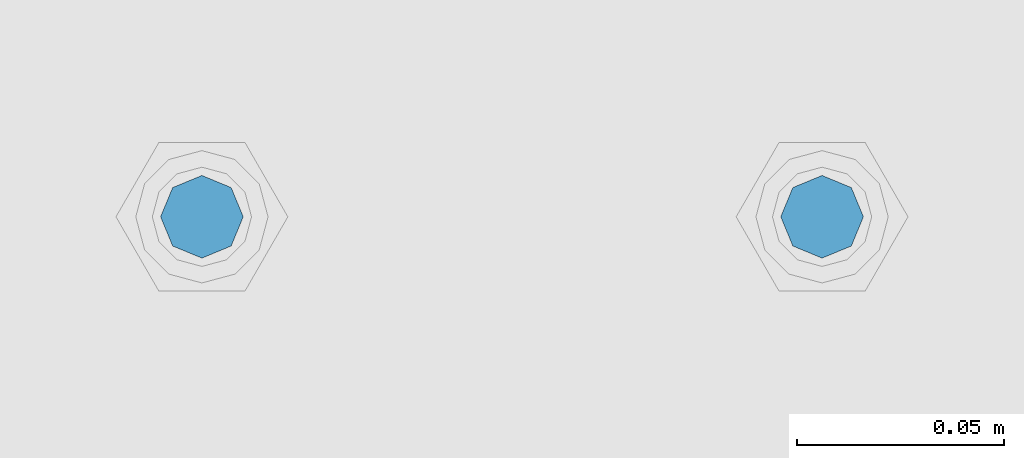
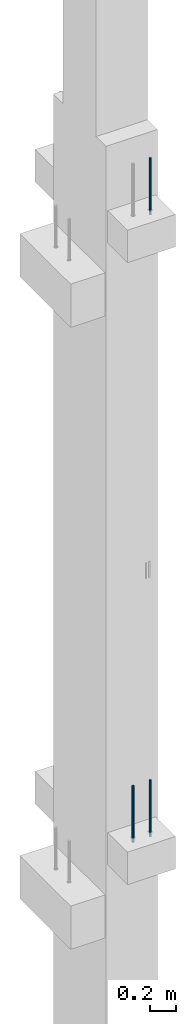
# One storey, part 9 of 41: 3 beams, 1 element without a shape of its own.
"""IFC2X3 building model written with IfcOpenShell, lengths in millimetres."""

from ifc_helpers import new_model, si_unit, frame, origin_with_axes, place, context, subcontext, project, spatial, faceted_brep, material, type_object, element, aggregate, save


model = new_model("IFC2X3")

# Units and contexts
model_context = context("Model", 3, precision=1e-05, world=origin_with_axes())
body_context = subcontext(model_context, "Body", "Model", "MODEL_VIEW")
ifc_project = project(units=[si_unit("LENGTHUNIT", "METRE", prefix="MILLI"), si_unit("AREAUNIT", "SQUARE_METRE"), si_unit("VOLUMEUNIT", "CUBIC_METRE"), si_unit("MASSUNIT", "GRAM", prefix="KILO"), si_unit("TIMEUNIT", "SECOND"), si_unit("PLANEANGLEUNIT", "RADIAN"), si_unit("SOLIDANGLEUNIT", "STERADIAN"), si_unit("THERMODYNAMICTEMPERATUREUNIT", "DEGREE_CELSIUS"), si_unit("LUMINOUSINTENSITYUNIT", "LUMEN")], contexts=[model_context])

# Site, building, storey
site_placement = place(None, frame((-177556.685383467, -198018.589999756, 1290.0), z_axis=(0.0, 0.0, 1.0), x_axis=(0.788225611989142, -0.615386370180835, 0.0)))
site = spatial("IfcSite", under=ifc_project, at=site_placement, CompositionType="ELEMENT")
building_placement = place(site_placement, origin_with_axes())
building = spatial("IfcBuilding", under=site, at=building_placement, Name="Undefined", CompositionType="ELEMENT")
storey_placement = place(building_placement, origin_with_axes())
storey = spatial("IfcBuildingStorey", under=building, at=storey_placement, Name="Undefined", CompositionType="ELEMENT", Elevation=0.0)

# Assembly, beams
assembly_placement = place(storey_placement, origin_with_axes())
assembly = element("IfcElementAssembly", 1, at=assembly_placement, inside=storey, AssemblyPlace="NOTDEFINED", PredefinedType="REINFORCEMENT_UNIT")
ifc_material = material(Name="STEEL/S235JR")
beam_type = type_object("IfcBeamType", PredefinedType="NOTDEFINED")
beam_1_placement = place(assembly_placement, frame((18494.3650953644, 264961.918298424, 11990.0), z_axis=(0.615386370178831, -0.788225611990706, 0.0), x_axis=(0.0, 0.0, -1.0)))
beam_1 = element("IfcBeam", 2, at=beam_1_placement, type_object=beam_type, material=ifc_material, context=body_context, shape_type="Brep", body=[
    faceted_brep([(4.88085788674653e-07, -10.0, -3.86498868465424e-08), (0.0, -7.07106819456385, -7.07106766643119), (524.0, -7.07106759562157, -7.07106811032281), (524.0, -9.99999978375854, -2.98430677503347e-07), (4.97872867461239e-11, -3.88578058618805e-15, -10.0), (524.0, 2.16212356463075e-07, -10.000000298518), (0.0, 7.07106742914766, -7.0710676664894), (524.0, 7.07106802810449, -7.07106811041012), (4.88085788674653e-07, 10.0, -3.86498868465424e-08), (524.0, 10.0000002162415, -2.98547092825174e-07), (0.0, 7.07106742919132, 7.07106795720756), (524.0, 7.0710680281336, 7.07106751331594), (-4.97872867461239e-11, 0.0, 10.0), (524.0, 2.16299667954445e-07, 9.99999970148201), (0.0, -7.07106819453475, 7.07106795729487), (524.0, -7.07106759559247, 7.07106751340325)], [[[0, 1, 2, 3]], [[1, 4, 5, 2]], [[4, 6, 7, 5]], [[6, 8, 9, 7]], [[8, 10, 11, 9]], [[10, 12, 13, 11]], [[12, 14, 15, 13]], [[14, 0, 3, 15]], [[5, 7, 9, 11, 13, 15, 3, 2]], [[14, 12, 10, 8, 6, 4, 1, 0]]]),
])
beam_2_placement = place(assembly_placement, frame((18376.1312535663, 264869.610342897, 11990.0), z_axis=(0.615386370178831, -0.788225611990706, 0.0), x_axis=(0.0, 0.0, -1.0)))
beam_2 = element("IfcBeam", 3, at=beam_2_placement, type_object=beam_type, material=ifc_material, context=body_context, shape_type="Brep", body=[
    faceted_brep([(4.88085788674653e-07, -10.0, -3.86498868465424e-08), (0.0, -7.07106819456385, -7.07106766643119), (524.0, -7.07106759562157, -7.07106811032281), (524.0, -9.99999978375854, -2.98430677503347e-07), (4.97872867461239e-11, -3.88578058618805e-15, -10.0), (524.0, 2.16212356463075e-07, -10.000000298518), (0.0, 7.07106742914766, -7.0710676664894), (524.0, 7.07106802810449, -7.07106811041012), (4.88085788674653e-07, 10.0, -3.86498868465424e-08), (524.0, 10.0000002162415, -2.98547092825174e-07), (0.0, 7.07106742919132, 7.07106795720756), (524.0, 7.0710680281336, 7.07106751331594), (-4.97872867461239e-11, 0.0, 10.0), (524.0, 2.16299667954445e-07, 9.99999970148201), (0.0, -7.07106819453475, 7.07106795729487), (524.0, -7.07106759559247, 7.07106751340325)], [[[0, 1, 2, 3]], [[1, 4, 5, 2]], [[4, 6, 7, 5]], [[6, 8, 9, 7]], [[8, 10, 11, 9]], [[10, 12, 13, 11]], [[12, 14, 15, 13]], [[14, 0, 3, 15]], [[5, 7, 9, 11, 13, 15, 3, 2]], [[14, 12, 10, 8, 6, 4, 1, 0]]]),
])
beam_3_placement = place(assembly_placement, frame((18494.3650953644, 264961.918298424, 17750.0), z_axis=(0.615386370178831, -0.788225611990706, 0.0), x_axis=(0.0, 0.0, -1.0)))
beam_3 = element("IfcBeam", 4, at=beam_3_placement, type_object=beam_type, material=ifc_material, context=body_context, shape_type="Brep", body=[
    faceted_brep([(4.88085788674653e-07, -10.0, -3.86498868465424e-08), (0.0, -7.07106819456385, -7.07106766643119), (524.0, -7.07106759562157, -7.07106811032281), (524.0, -9.99999978375854, -2.98430677503347e-07), (4.97872867461239e-11, -3.88578058618805e-15, -10.0), (524.0, 2.16212356463075e-07, -10.000000298518), (0.0, 7.07106742914766, -7.0710676664894), (524.0, 7.07106802810449, -7.07106811041012), (4.88085788674653e-07, 10.0, -3.86498868465424e-08), (524.0, 10.0000002162415, -2.98547092825174e-07), (0.0, 7.07106742919132, 7.07106795720756), (524.0, 7.0710680281336, 7.07106751331594), (-4.97872867461239e-11, 0.0, 10.0), (524.0, 2.16299667954445e-07, 9.99999970148201), (0.0, -7.07106819453475, 7.07106795729487), (524.0, -7.07106759559247, 7.07106751340325)], [[[0, 1, 2, 3]], [[1, 4, 5, 2]], [[4, 6, 7, 5]], [[6, 8, 9, 7]], [[8, 10, 11, 9]], [[10, 12, 13, 11]], [[12, 14, 15, 13]], [[14, 0, 3, 15]], [[5, 7, 9, 11, 13, 15, 3, 2]], [[14, 12, 10, 8, 6, 4, 1, 0]]]),
])
aggregate(assembly, [beam_1, beam_2, beam_3])

save(model, "model.ifc")
